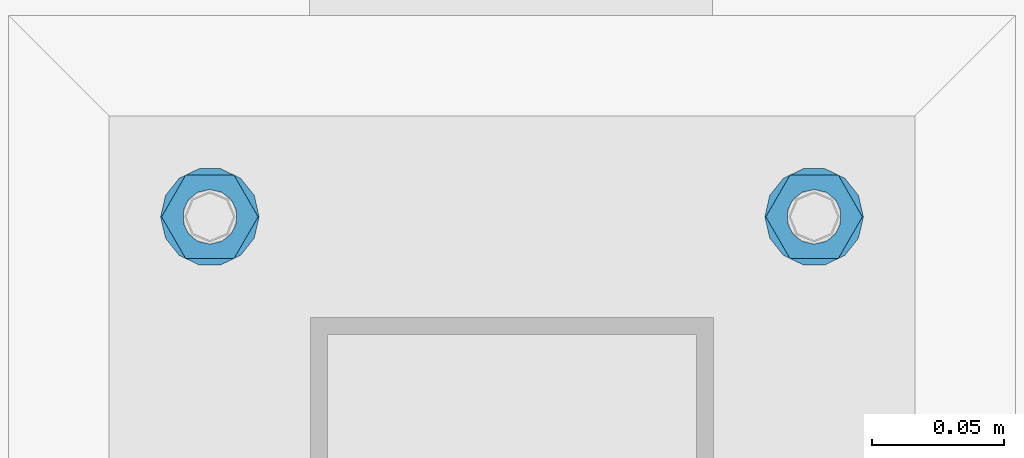
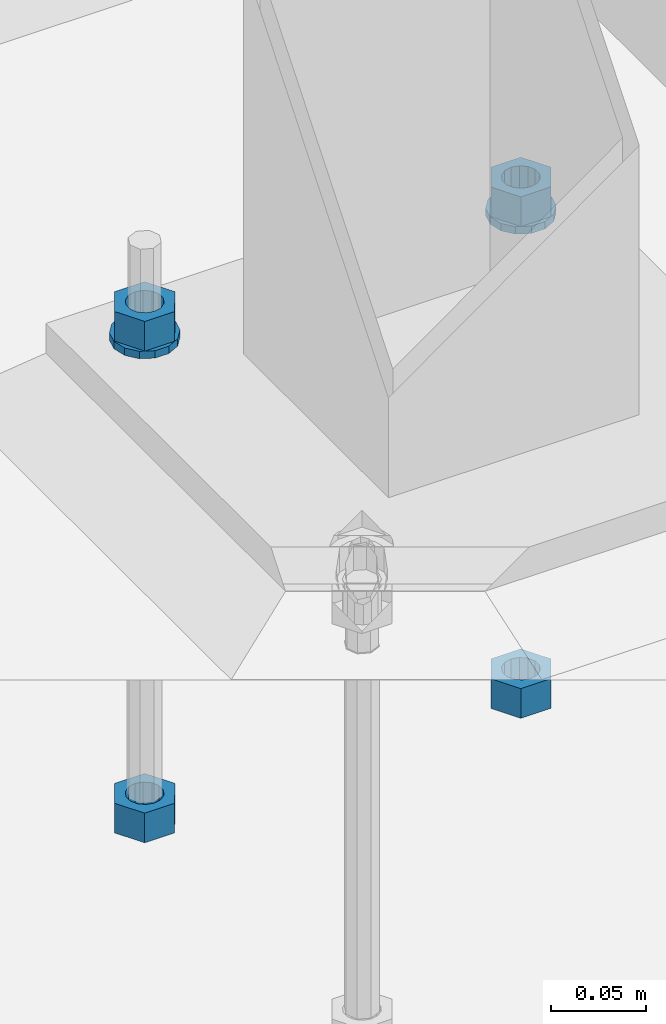
# One storey, part 963 of 1179: 6 beams, 1 element without a shape of its own.
"""IFC2X3 building model written with IfcOpenShell, lengths in millimetres."""

from ifc_helpers import new_model, si_unit, frame, origin_with_axes, place, context, subcontext, project, spatial, faceted_brep, material, type_object, element, aggregate, save


model = new_model("IFC2X3")

# Units and contexts
model_context = context("Model", 3, precision=1e-05, world=origin_with_axes())
body_context = subcontext(model_context, "Body", "Model", "MODEL_VIEW")
ifc_project = project(units=[si_unit("LENGTHUNIT", "METRE", prefix="MILLI"), si_unit("AREAUNIT", "SQUARE_METRE"), si_unit("VOLUMEUNIT", "CUBIC_METRE"), si_unit("MASSUNIT", "GRAM", prefix="KILO"), si_unit("TIMEUNIT", "SECOND"), si_unit("PLANEANGLEUNIT", "RADIAN"), si_unit("SOLIDANGLEUNIT", "STERADIAN"), si_unit("THERMODYNAMICTEMPERATUREUNIT", "DEGREE_CELSIUS"), si_unit("LUMINOUSINTENSITYUNIT", "LUMEN")], contexts=[model_context])

# Site, building, storey
site_placement = place(None, origin_with_axes())
site = spatial("IfcSite", under=ifc_project, at=site_placement, CompositionType="ELEMENT")
building_placement = place(site_placement, origin_with_axes())
building = spatial("IfcBuilding", under=site, at=building_placement, Name="Undefined", CompositionType="ELEMENT")
storey_placement = place(building_placement, origin_with_axes())
storey = spatial("IfcBuildingStorey", under=building, at=storey_placement, Name="Undefined", CompositionType="ELEMENT", Elevation=0.0)

# Assembly, beams
assembly_placement = place(storey_placement, origin_with_axes())
assembly = element("IfcElementAssembly", 1, at=assembly_placement, inside=storey, Name="TEMPLATE", AssemblyPlace="NOTDEFINED", PredefinedType="RIGID_FRAME")
ifc_material = material(Name="STEEL/A36")
beam_type_1 = type_object("IfcBeamType", Name="3/4_HEAVY_HEX_NUT", PredefinedType="NOTDEFINED")
beam_1_placement = place(assembly_placement, frame((36969.7, 2349.5, -731.8375), z_axis=(0.0, -1.0, 0.0), x_axis=(0.0, 0.0, -1.0)))
beam_1 = element("IfcBeam", 2, at=beam_1_placement, type_object=beam_type_1, material=ifc_material, Name="NUT", ObjectType="3/4_HEAVY_HEX_NUT", context=body_context, shape_type="Brep", body=[
    faceted_brep([(0.0, -18.2600002288818, 0.0), (0.0, -9.13000011444092, -15.8100004196167), (19.0499999999865, -9.13000011444092, -15.8100004196167), (19.0499999999865, -18.2600002288818, 0.0), (0.0, 9.13000011444092, -15.8100004196167), (19.0499999999865, 9.13000011444092, -15.8100004196167), (0.0, 18.2600002288818, 0.0), (19.0499999999865, 18.2600002288818, 0.0), (0.0, 9.13000011444092, 15.8100004196167), (19.0499999999865, 9.13000011444092, 15.8100004196167), (0.0, -9.13000011444092, 15.8100004196167), (19.0499999999865, -9.13000011444092, 15.8100004196167), (0.0, 0.0, 10.3199996948242), (0.0, 4.47768005528246, 9.29799844179979), (19.0499999999865, 4.47768005528246, 9.29799844179979), (19.0499999999865, 0.0, 10.3199996948242), (0.0, 8.068500660474, 6.43441456490837), (19.0499999999865, 8.068500660474, 6.43441456490837), (0.0, 10.0612557561919, 2.29641597052068), (19.0499999999865, 10.0612557561919, 2.29641597052068), (0.0, 10.0612557561919, -2.29641597052068), (19.0499999999865, 10.0612557561919, -2.29641597052068), (0.0, 8.068500660474, -6.43441456490837), (19.0499999999865, 8.068500660474, -6.43441456490837), (0.0, 4.47768005528246, -9.29799844179979), (19.0499999999865, 4.47768005528246, -9.29799844179979), (0.0, 0.0, -10.3199996948242), (19.0499999999865, 0.0, -10.3199996948242), (0.0, -4.47768005528246, -9.29799844179979), (19.0499999999865, -4.47768005528246, -9.29799844179979), (0.0, -8.068500660474, -6.43441456490837), (19.0499999999865, -8.068500660474, -6.43441456490837), (0.0, -10.0612557561919, -2.29641597052068), (19.0499999999865, -10.0612557561919, -2.29641597052068), (0.0, -10.0612557561919, 2.29641597052068), (19.0499999999865, -10.0612557561919, 2.29641597052068), (0.0, -8.068500660474, 6.43441456490837), (19.0499999999865, -8.068500660474, 6.43441456490837), (0.0, -4.47768005528246, 9.29799844179979), (19.0499999999865, -4.47768005528246, 9.29799844179979)], [[[0, 1, 2, 3]], [[1, 4, 5, 2]], [[4, 6, 7, 5]], [[6, 8, 9, 7]], [[8, 10, 11, 9]], [[10, 0, 3, 11]], [[12, 13, 14, 15]], [[13, 16, 17, 14]], [[16, 18, 19, 17]], [[18, 20, 21, 19]], [[20, 22, 23, 21]], [[22, 24, 25, 23]], [[24, 26, 27, 25]], [[26, 28, 29, 27]], [[28, 30, 31, 29]], [[30, 32, 33, 31]], [[32, 34, 35, 33]], [[34, 36, 37, 35]], [[36, 38, 39, 37]], [[38, 12, 15, 39]], [[5, 7, 9, 11, 3, 2], [17, 19, 21, 23, 25, 27, 29, 31, 33, 35, 37, 39, 15, 14]], [[10, 8, 6, 4, 1, 0], [38, 36, 34, 32, 30, 28, 26, 24, 22, 20, 18, 16, 13, 12]]]),
])
beam_2_placement = place(assembly_placement, frame((36969.7, 2349.5, -1047.75), z_axis=(0.0, -1.0, 0.0), x_axis=(0.0, 0.0, -1.0)))
beam_2 = element("IfcBeam", 3, at=beam_2_placement, type_object=beam_type_1, material=ifc_material, Name="NUT", ObjectType="3/4_HEAVY_HEX_NUT", context=body_context, shape_type="Brep", body=[
    faceted_brep([(0.0, -18.2600002288818, 0.0), (0.0, -9.13000011444092, -15.8100004196167), (19.0499999999865, -9.13000011444092, -15.8100004196167), (19.0499999999865, -18.2600002288818, 0.0), (0.0, 9.13000011444092, -15.8100004196167), (19.0499999999865, 9.13000011444092, -15.8100004196167), (0.0, 18.2600002288818, 0.0), (19.0499999999865, 18.2600002288818, 0.0), (0.0, 9.13000011444092, 15.8100004196167), (19.0499999999865, 9.13000011444092, 15.8100004196167), (0.0, -9.13000011444092, 15.8100004196167), (19.0499999999865, -9.13000011444092, 15.8100004196167), (0.0, 0.0, 10.3199996948242), (0.0, 4.47768005528246, 9.29799844179979), (19.0499999999865, 4.47768005528246, 9.29799844179979), (19.0499999999865, 0.0, 10.3199996948242), (0.0, 8.068500660474, 6.43441456490837), (19.0499999999865, 8.068500660474, 6.43441456490837), (0.0, 10.0612557561919, 2.29641597052068), (19.0499999999865, 10.0612557561919, 2.29641597052068), (0.0, 10.0612557561919, -2.29641597052068), (19.0499999999865, 10.0612557561919, -2.29641597052068), (0.0, 8.068500660474, -6.43441456490837), (19.0499999999865, 8.068500660474, -6.43441456490837), (0.0, 4.47768005528246, -9.29799844179979), (19.0499999999865, 4.47768005528246, -9.29799844179979), (0.0, 0.0, -10.3199996948242), (19.0499999999865, 0.0, -10.3199996948242), (0.0, -4.47768005528246, -9.29799844179979), (19.0499999999865, -4.47768005528246, -9.29799844179979), (0.0, -8.068500660474, -6.43441456490837), (19.0499999999865, -8.068500660474, -6.43441456490837), (0.0, -10.0612557561919, -2.29641597052068), (19.0499999999865, -10.0612557561919, -2.29641597052068), (0.0, -10.0612557561919, 2.29641597052068), (19.0499999999865, -10.0612557561919, 2.29641597052068), (0.0, -8.068500660474, 6.43441456490837), (19.0499999999865, -8.068500660474, 6.43441456490837), (0.0, -4.47768005528246, 9.29799844179979), (19.0499999999865, -4.47768005528246, 9.29799844179979)], [[[0, 1, 2, 3]], [[1, 4, 5, 2]], [[4, 6, 7, 5]], [[6, 8, 9, 7]], [[8, 10, 11, 9]], [[10, 0, 3, 11]], [[12, 13, 14, 15]], [[13, 16, 17, 14]], [[16, 18, 19, 17]], [[18, 20, 21, 19]], [[20, 22, 23, 21]], [[22, 24, 25, 23]], [[24, 26, 27, 25]], [[26, 28, 29, 27]], [[28, 30, 31, 29]], [[30, 32, 33, 31]], [[32, 34, 35, 33]], [[34, 36, 37, 35]], [[36, 38, 39, 37]], [[38, 12, 15, 39]], [[5, 7, 9, 11, 3, 2], [17, 19, 21, 23, 25, 27, 29, 31, 33, 35, 37, 39, 15, 14]], [[10, 8, 6, 4, 1, 0], [38, 36, 34, 32, 30, 28, 26, 24, 22, 20, 18, 16, 13, 12]]]),
])
beam_3_placement = place(assembly_placement, frame((37198.3, 2349.5, -731.8375), z_axis=(0.0, 1.0, 0.0), x_axis=(0.0, 0.0, -1.0)))
beam_3 = element("IfcBeam", 4, at=beam_3_placement, type_object=beam_type_1, material=ifc_material, Name="NUT", ObjectType="3/4_HEAVY_HEX_NUT", context=body_context, shape_type="Brep", body=[
    faceted_brep([(0.0, -18.2600002288818, 0.0), (0.0, -9.13000011444092, -15.8100004196167), (19.0499999999865, -9.13000011444092, -15.8100004196167), (19.0499999999865, -18.2600002288818, 0.0), (0.0, 9.13000011444092, -15.8100004196167), (19.0499999999865, 9.13000011444092, -15.8100004196167), (0.0, 18.2600002288818, 0.0), (19.0499999999865, 18.2600002288818, 0.0), (0.0, 9.13000011444092, 15.8100004196167), (19.0499999999865, 9.13000011444092, 15.8100004196167), (0.0, -9.13000011444092, 15.8100004196167), (19.0499999999865, -9.13000011444092, 15.8100004196167), (0.0, 0.0, 10.3199996948242), (0.0, 4.47768005528246, 9.29799844179979), (19.0499999999865, 4.47768005528246, 9.29799844179979), (19.0499999999865, 0.0, 10.3199996948242), (0.0, 8.068500660474, 6.43441456490837), (19.0499999999865, 8.068500660474, 6.43441456490837), (0.0, 10.0612557561919, 2.29641597052068), (19.0499999999865, 10.0612557561919, 2.29641597052068), (0.0, 10.0612557561919, -2.29641597052068), (19.0499999999865, 10.0612557561919, -2.29641597052068), (0.0, 8.068500660474, -6.43441456490837), (19.0499999999865, 8.068500660474, -6.43441456490837), (0.0, 4.47768005528246, -9.29799844179979), (19.0499999999865, 4.47768005528246, -9.29799844179979), (0.0, 0.0, -10.3199996948242), (19.0499999999865, 0.0, -10.3199996948242), (0.0, -4.47768005528246, -9.29799844179979), (19.0499999999865, -4.47768005528246, -9.29799844179979), (0.0, -8.068500660474, -6.43441456490837), (19.0499999999865, -8.068500660474, -6.43441456490837), (0.0, -10.0612557561919, -2.29641597052068), (19.0499999999865, -10.0612557561919, -2.29641597052068), (0.0, -10.0612557561919, 2.29641597052068), (19.0499999999865, -10.0612557561919, 2.29641597052068), (0.0, -8.068500660474, 6.43441456490837), (19.0499999999865, -8.068500660474, 6.43441456490837), (0.0, -4.47768005528246, 9.29799844179979), (19.0499999999865, -4.47768005528246, 9.29799844179979)], [[[0, 1, 2, 3]], [[1, 4, 5, 2]], [[4, 6, 7, 5]], [[6, 8, 9, 7]], [[8, 10, 11, 9]], [[10, 0, 3, 11]], [[12, 13, 14, 15]], [[13, 16, 17, 14]], [[16, 18, 19, 17]], [[18, 20, 21, 19]], [[20, 22, 23, 21]], [[22, 24, 25, 23]], [[24, 26, 27, 25]], [[26, 28, 29, 27]], [[28, 30, 31, 29]], [[30, 32, 33, 31]], [[32, 34, 35, 33]], [[34, 36, 37, 35]], [[36, 38, 39, 37]], [[38, 12, 15, 39]], [[5, 7, 9, 11, 3, 2], [17, 19, 21, 23, 25, 27, 29, 31, 33, 35, 37, 39, 15, 14]], [[10, 8, 6, 4, 1, 0], [38, 36, 34, 32, 30, 28, 26, 24, 22, 20, 18, 16, 13, 12]]]),
])
beam_4_placement = place(assembly_placement, frame((37198.3, 2349.5, -1047.75), z_axis=(0.0, 1.0, 0.0), x_axis=(0.0, 0.0, -1.0)))
beam_4 = element("IfcBeam", 5, at=beam_4_placement, type_object=beam_type_1, material=ifc_material, Name="NUT", ObjectType="3/4_HEAVY_HEX_NUT", context=body_context, shape_type="Brep", body=[
    faceted_brep([(0.0, -18.2600002288818, 0.0), (0.0, -9.13000011444092, -15.8100004196167), (19.0499999999865, -9.13000011444092, -15.8100004196167), (19.0499999999865, -18.2600002288818, 0.0), (0.0, 9.13000011444092, -15.8100004196167), (19.0499999999865, 9.13000011444092, -15.8100004196167), (0.0, 18.2600002288818, 0.0), (19.0499999999865, 18.2600002288818, 0.0), (0.0, 9.13000011444092, 15.8100004196167), (19.0499999999865, 9.13000011444092, 15.8100004196167), (0.0, -9.13000011444092, 15.8100004196167), (19.0499999999865, -9.13000011444092, 15.8100004196167), (0.0, 0.0, 10.3199996948242), (0.0, 4.47768005528246, 9.29799844179979), (19.0499999999865, 4.47768005528246, 9.29799844179979), (19.0499999999865, 0.0, 10.3199996948242), (0.0, 8.068500660474, 6.43441456490837), (19.0499999999865, 8.068500660474, 6.43441456490837), (0.0, 10.0612557561919, 2.29641597052068), (19.0499999999865, 10.0612557561919, 2.29641597052068), (0.0, 10.0612557561919, -2.29641597052068), (19.0499999999865, 10.0612557561919, -2.29641597052068), (0.0, 8.068500660474, -6.43441456490837), (19.0499999999865, 8.068500660474, -6.43441456490837), (0.0, 4.47768005528246, -9.29799844179979), (19.0499999999865, 4.47768005528246, -9.29799844179979), (0.0, 0.0, -10.3199996948242), (19.0499999999865, 0.0, -10.3199996948242), (0.0, -4.47768005528246, -9.29799844179979), (19.0499999999865, -4.47768005528246, -9.29799844179979), (0.0, -8.068500660474, -6.43441456490837), (19.0499999999865, -8.068500660474, -6.43441456490837), (0.0, -10.0612557561919, -2.29641597052068), (19.0499999999865, -10.0612557561919, -2.29641597052068), (0.0, -10.0612557561919, 2.29641597052068), (19.0499999999865, -10.0612557561919, 2.29641597052068), (0.0, -8.068500660474, 6.43441456490837), (19.0499999999865, -8.068500660474, 6.43441456490837), (0.0, -4.47768005528246, 9.29799844179979), (19.0499999999865, -4.47768005528246, 9.29799844179979)], [[[0, 1, 2, 3]], [[1, 4, 5, 2]], [[4, 6, 7, 5]], [[6, 8, 9, 7]], [[8, 10, 11, 9]], [[10, 0, 3, 11]], [[12, 13, 14, 15]], [[13, 16, 17, 14]], [[16, 18, 19, 17]], [[18, 20, 21, 19]], [[20, 22, 23, 21]], [[22, 24, 25, 23]], [[24, 26, 27, 25]], [[26, 28, 29, 27]], [[28, 30, 31, 29]], [[30, 32, 33, 31]], [[32, 34, 35, 33]], [[34, 36, 37, 35]], [[36, 38, 39, 37]], [[38, 12, 15, 39]], [[5, 7, 9, 11, 3, 2], [17, 19, 21, 23, 25, 27, 29, 31, 33, 35, 37, 39, 15, 14]], [[10, 8, 6, 4, 1, 0], [38, 36, 34, 32, 30, 28, 26, 24, 22, 20, 18, 16, 13, 12]]]),
])
beam_type_2 = type_object("IfcBeamType", Name="3/4_WASHER", PredefinedType="NOTDEFINED")
beam_5_placement = place(assembly_placement, frame((36969.7, 2349.5, -750.8875), z_axis=(0.0, -1.0, 0.0), x_axis=(0.0, 0.0, -1.0)))
beam_5 = element("IfcBeam", 6, at=beam_5_placement, type_object=beam_type_2, material=ifc_material, Name="WASHER", ObjectType="3/4_WASHER", context=body_context, shape_type="Brep", body=[
    faceted_brep([(0.0, -18.6499996185303, 0.0), (0.0, -16.8030690426895, -8.09193156902893), (4.76249999999993, -16.8030690426895, -8.09193156902893), (4.76249999999993, -18.6499996185303, 0.0), (0.0, -11.6280845668225, -14.5811568497838), (4.76249999999993, -11.6280845668225, -14.5811568497838), (0.0, -4.15001533339819, -18.1824051902859), (4.76249999999993, -4.15001533339819, -18.1824051902859), (0.0, 4.15001533339819, -18.1824051902859), (4.76249999999993, 4.15001533339819, -18.1824051902859), (0.0, 11.6280845668225, -14.5811568497838), (4.76249999999993, 11.6280845668225, -14.5811568497838), (0.0, 16.8030690426895, -8.09193156902893), (4.76249999999993, 16.8030690426895, -8.09193156902893), (0.0, 18.6499996185303, 0.0), (4.76249999999993, 18.6499996185303, 0.0), (0.0, 16.8030690426895, 8.09193156902893), (4.76249999999993, 16.8030690426895, 8.09193156902893), (0.0, 11.6280845668225, 14.5811568497838), (4.76249999999993, 11.6280845668225, 14.5811568497838), (0.0, 4.15001533339819, 18.1824051902859), (4.76249999999993, 4.15001533339819, 18.1824051902859), (0.0, -4.15001533339819, 18.1824051902859), (4.76249999999993, -4.15001533339819, 18.1824051902859), (0.0, -11.6280845668225, 14.5811568497838), (4.76249999999993, -11.6280845668225, 14.5811568497838), (0.0, -16.8030690426895, 8.09193156902893), (4.76249999999993, -16.8030690426895, 8.09193156902893), (0.0, 0.0, 10.3199996948242), (0.0, 4.47768005528246, 9.29799844179979), (4.76249999999993, 4.47768005527905, 9.29799844179888), (4.76249999999993, 0.0, 10.3199996948242), (0.0, 8.068500660474, 6.43441456490837), (4.76249999999993, 8.06850066047627, 6.43441456490837), (0.0, 10.0612557561919, 2.29641597052068), (4.76249999999993, 10.0612557561908, 2.29641597052114), (0.0, 10.0612557561919, -2.29641597052068), (4.76249999999993, 10.0612557561908, -2.29641597052114), (0.0, 8.068500660474, -6.43441456490837), (4.76249999999993, 8.06850066047627, -6.43441456490791), (0.0, 4.47768005528246, -9.29799844179979), (4.76249999999993, 4.47768005527905, -9.29799844179888), (0.0, 0.0, -10.3199996948242), (4.76249999999993, 0.0, -10.3199996948242), (0.0, -4.47768005528246, -9.29799844179979), (4.76249999999993, -4.47768005527905, -9.29799844179888), (0.0, -8.068500660474, -6.43441456490837), (4.76249999999993, -8.06850066047627, -6.43441456490837), (0.0, -10.0612557561919, -2.29641597052068), (4.76249999999993, -10.0612557561908, -2.29641597052114), (0.0, -10.0612557561919, 2.29641597052068), (4.76249999999993, -10.0612557561908, 2.29641597052114), (0.0, -8.068500660474, 6.43441456490837), (4.76249999999993, -8.06850066047627, 6.43441456490791), (0.0, -4.47768005528246, 9.29799844179979), (4.76249999999993, -4.47768005527905, 9.29799844179888)], [[[0, 1, 2, 3]], [[1, 4, 5, 2]], [[4, 6, 7, 5]], [[6, 8, 9, 7]], [[8, 10, 11, 9]], [[10, 12, 13, 11]], [[12, 14, 15, 13]], [[14, 16, 17, 15]], [[16, 18, 19, 17]], [[18, 20, 21, 19]], [[20, 22, 23, 21]], [[22, 24, 25, 23]], [[24, 26, 27, 25]], [[26, 0, 3, 27]], [[28, 29, 30, 31]], [[29, 32, 33, 30]], [[32, 34, 35, 33]], [[34, 36, 37, 35]], [[36, 38, 39, 37]], [[38, 40, 41, 39]], [[40, 42, 43, 41]], [[42, 44, 45, 43]], [[44, 46, 47, 45]], [[46, 48, 49, 47]], [[48, 50, 51, 49]], [[50, 52, 53, 51]], [[52, 54, 55, 53]], [[54, 28, 31, 55]], [[5, 7, 9, 11, 13, 15, 17, 19, 21, 23, 25, 27, 3, 2], [33, 35, 37, 39, 41, 43, 45, 47, 49, 51, 53, 55, 31, 30]], [[26, 24, 22, 20, 18, 16, 14, 12, 10, 8, 6, 4, 1, 0], [54, 52, 50, 48, 46, 44, 42, 40, 38, 36, 34, 32, 29, 28]]]),
])
beam_6_placement = place(assembly_placement, frame((37198.3, 2349.5, -750.8875), z_axis=(0.0, 1.0, 0.0), x_axis=(0.0, 0.0, -1.0)))
beam_6 = element("IfcBeam", 7, at=beam_6_placement, type_object=beam_type_2, material=ifc_material, Name="WASHER", ObjectType="3/4_WASHER", context=body_context, shape_type="Brep", body=[
    faceted_brep([(0.0, -18.6499996185303, 0.0), (0.0, -16.8030690426895, -8.09193156902893), (4.76249999999993, -16.8030690426895, -8.09193156902893), (4.76249999999993, -18.6499996185303, 0.0), (0.0, -11.6280845668225, -14.5811568497838), (4.76249999999993, -11.6280845668225, -14.5811568497838), (0.0, -4.15001533339819, -18.1824051902859), (4.76249999999993, -4.15001533339819, -18.1824051902859), (0.0, 4.15001533339819, -18.1824051902859), (4.76249999999993, 4.15001533339819, -18.1824051902859), (0.0, 11.6280845668225, -14.5811568497838), (4.76249999999993, 11.6280845668225, -14.5811568497838), (0.0, 16.8030690426895, -8.09193156902893), (4.76249999999993, 16.8030690426895, -8.09193156902893), (0.0, 18.6499996185303, 0.0), (4.76249999999993, 18.6499996185303, 0.0), (0.0, 16.8030690426895, 8.09193156902893), (4.76249999999993, 16.8030690426895, 8.09193156902893), (0.0, 11.6280845668225, 14.5811568497838), (4.76249999999993, 11.6280845668225, 14.5811568497838), (0.0, 4.15001533339819, 18.1824051902859), (4.76249999999993, 4.15001533339819, 18.1824051902859), (0.0, -4.15001533339819, 18.1824051902859), (4.76249999999993, -4.15001533339819, 18.1824051902859), (0.0, -11.6280845668225, 14.5811568497838), (4.76249999999993, -11.6280845668225, 14.5811568497838), (0.0, -16.8030690426895, 8.09193156902893), (4.76249999999993, -16.8030690426895, 8.09193156902893), (0.0, 0.0, 10.3199996948242), (0.0, 4.47768005528246, 9.29799844179979), (4.76249999999993, 4.47768005527905, 9.29799844179888), (4.76249999999993, 0.0, 10.3199996948242), (0.0, 8.068500660474, 6.43441456490837), (4.76249999999993, 8.06850066047627, 6.43441456490837), (0.0, 10.0612557561919, 2.29641597052068), (4.76249999999993, 10.0612557561908, 2.29641597052114), (0.0, 10.0612557561919, -2.29641597052068), (4.76249999999993, 10.0612557561908, -2.29641597052114), (0.0, 8.068500660474, -6.43441456490837), (4.76249999999993, 8.06850066047627, -6.43441456490791), (0.0, 4.47768005528246, -9.29799844179979), (4.76249999999993, 4.47768005527905, -9.29799844179888), (0.0, 0.0, -10.3199996948242), (4.76249999999993, 0.0, -10.3199996948242), (0.0, -4.47768005528246, -9.29799844179979), (4.76249999999993, -4.47768005527905, -9.29799844179888), (0.0, -8.068500660474, -6.43441456490837), (4.76249999999993, -8.06850066047627, -6.43441456490837), (0.0, -10.0612557561919, -2.29641597052068), (4.76249999999993, -10.0612557561908, -2.29641597052114), (0.0, -10.0612557561919, 2.29641597052068), (4.76249999999993, -10.0612557561908, 2.29641597052114), (0.0, -8.068500660474, 6.43441456490837), (4.76249999999993, -8.06850066047627, 6.43441456490791), (0.0, -4.47768005528246, 9.29799844179979), (4.76249999999993, -4.47768005527905, 9.29799844179888)], [[[0, 1, 2, 3]], [[1, 4, 5, 2]], [[4, 6, 7, 5]], [[6, 8, 9, 7]], [[8, 10, 11, 9]], [[10, 12, 13, 11]], [[12, 14, 15, 13]], [[14, 16, 17, 15]], [[16, 18, 19, 17]], [[18, 20, 21, 19]], [[20, 22, 23, 21]], [[22, 24, 25, 23]], [[24, 26, 27, 25]], [[26, 0, 3, 27]], [[28, 29, 30, 31]], [[29, 32, 33, 30]], [[32, 34, 35, 33]], [[34, 36, 37, 35]], [[36, 38, 39, 37]], [[38, 40, 41, 39]], [[40, 42, 43, 41]], [[42, 44, 45, 43]], [[44, 46, 47, 45]], [[46, 48, 49, 47]], [[48, 50, 51, 49]], [[50, 52, 53, 51]], [[52, 54, 55, 53]], [[54, 28, 31, 55]], [[5, 7, 9, 11, 13, 15, 17, 19, 21, 23, 25, 27, 3, 2], [33, 35, 37, 39, 41, 43, 45, 47, 49, 51, 53, 55, 31, 30]], [[26, 24, 22, 20, 18, 16, 14, 12, 10, 8, 6, 4, 1, 0], [54, 52, 50, 48, 46, 44, 42, 40, 38, 36, 34, 32, 29, 28]]]),
])
aggregate(assembly, [beam_1, beam_5, beam_2, beam_3, beam_6, beam_4])

save(model, "model.ifc")
